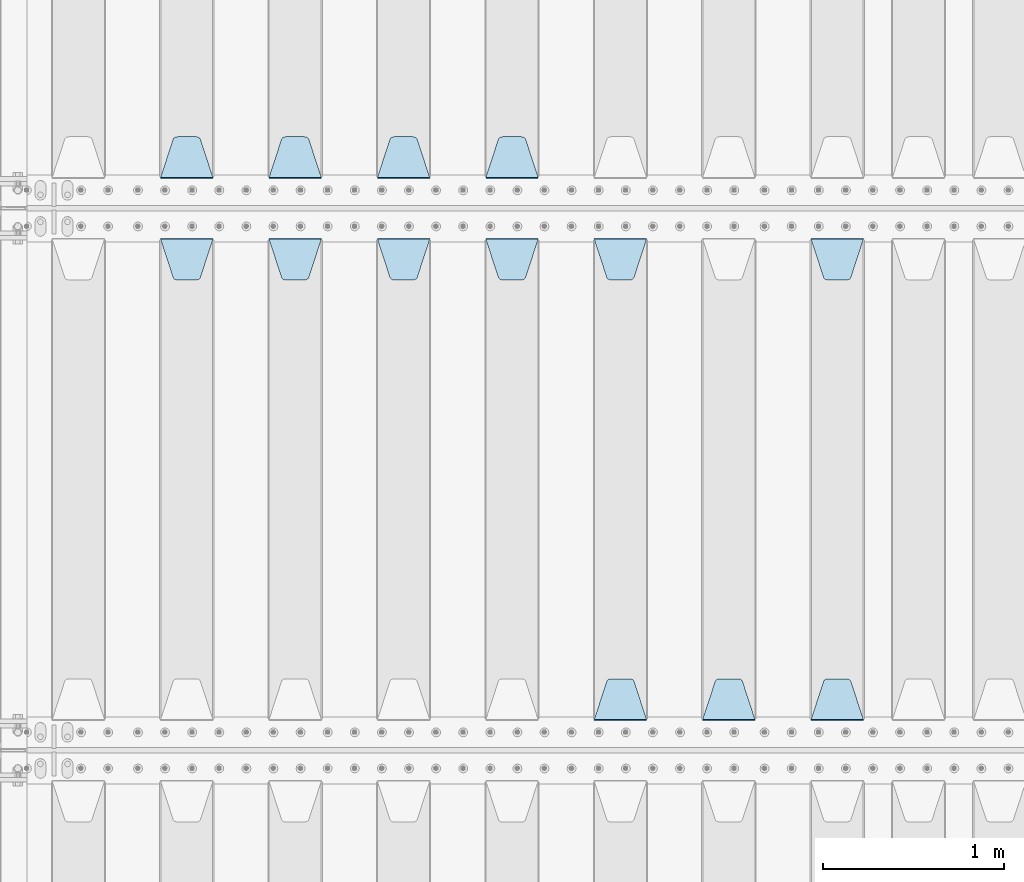
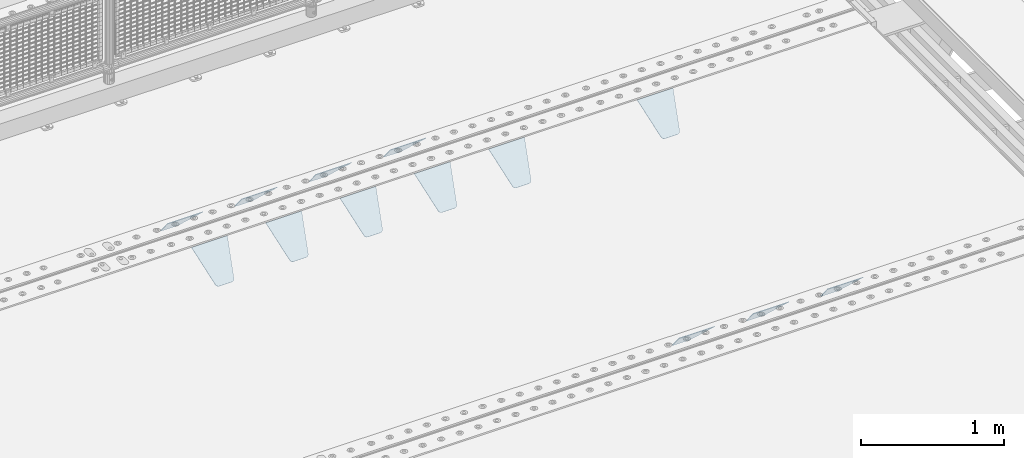
# One storey, part 245 of 270: 13 plates.
"""IFC2X3 building model written with IfcOpenShell, lengths in millimetres."""

from ifc_helpers import new_model, si_unit, frame, origin_with_axes, place, context, subcontext, project, spatial, faceted_brep, material, type_object, element, save


model = new_model("IFC2X3")

# Units and contexts
model_context = context("Model", 3, precision=1e-05, world=origin_with_axes())
body_context = subcontext(model_context, "Body", "Model", "MODEL_VIEW")
ifc_project = project(units=[si_unit("LENGTHUNIT", "METRE", prefix="MILLI"), si_unit("AREAUNIT", "SQUARE_METRE"), si_unit("VOLUMEUNIT", "CUBIC_METRE"), si_unit("MASSUNIT", "GRAM", prefix="KILO"), si_unit("TIMEUNIT", "SECOND"), si_unit("PLANEANGLEUNIT", "RADIAN"), si_unit("SOLIDANGLEUNIT", "STERADIAN"), si_unit("THERMODYNAMICTEMPERATUREUNIT", "DEGREE_CELSIUS"), si_unit("LUMINOUSINTENSITYUNIT", "LUMEN")], contexts=[model_context])

# Site, building, storey
site_placement = place(None, origin_with_axes())
site = spatial("IfcSite", under=ifc_project, at=site_placement, CompositionType="ELEMENT")
building_placement = place(site_placement, origin_with_axes())
building = spatial("IfcBuilding", under=site, at=building_placement, Name="Standard", CompositionType="ELEMENT")
storey_placement = place(building_placement, origin_with_axes())
storey = spatial("IfcBuildingStorey", under=building, at=storey_placement, Name="Undefined", CompositionType="ELEMENT", Elevation=0.0)

# Plates
ifc_material = material(Name="STEEL/S355N")
plate_type = type_object("IfcPlateType", PredefinedType="NOTDEFINED")
plate_1_placement = place(storey_placement, frame((17015.0, -17831.767766953, -1.76776695296758), z_axis=(0.0, 0.707106781186547, -0.707106781186548), x_axis=(-1.0, 0.0, 0.0)))
element("IfcPlate", 1, at=plate_1_placement, inside=storey, type_object=plate_type, material=ifc_material, context=body_context, shape_type="Brep", body=[
    faceted_brep([(0.0, -2.5, 0.0), (69.345504679477, -2.5, 300.171731424831), (69.345504679477, 2.5, 300.171731424831), (0.0, 2.5, 0.0), (70.9274061199576, -2.5, 304.8974424154), (70.9274061199576, 2.5, 304.8974424154), (73.3818627772307, -2.49999999999818, 309.234538108527), (73.3818627772307, 2.50000000000182, 309.234538108527), (76.6187032999551, -2.5, 313.023683126103), (76.6187032999551, 2.5, 313.023683126103), (80.5190132704993, -2.5, 316.125672595372), (80.5190132704993, 2.50000000000182, 316.125672595372), (84.9395038596849, -2.49999999999818, 318.426546230476), (84.9395038596849, 2.5, 318.426546230476), (89.7177759439219, -2.49999999999818, 319.841774983275), (89.7177759439219, 2.50000000000182, 319.841774983275), (94.678286292652, -2.5, 320.319366455078), (94.678286292652, 2.5, 320.319366455078), (195.321713707348, -2.5, 320.319366455078), (195.321713707348, 2.5, 320.319366455078), (200.282224056078, -2.49999999999818, 319.841774983275), (200.282224056078, 2.50000000000182, 319.841774983275), (205.060496140315, -2.5, 318.426546230476), (205.060496140315, 2.5, 318.426546230476), (209.480986729501, -2.5, 316.12567259537), (209.480986729501, 2.50000000000182, 316.12567259537), (213.381296700045, -2.5, 313.023683126103), (213.381296700045, 2.5, 313.023683126103), (216.618137222769, -2.49999999999818, 309.234538108525), (216.618137222769, 2.50000000000182, 309.234538108527), (219.072593880042, -2.49999999999818, 304.897442415398), (219.072593880042, 2.50000000000182, 304.897442415397), (220.654495320523, -2.5, 300.171731424831), (220.654495320523, 2.5, 300.171731424831), (290.0, -2.49999999999818, 0.0), (290.0, 2.5, 0.0)], [[[0, 1, 2, 3]], [[1, 4, 5, 2]], [[4, 6, 7, 5]], [[6, 8, 9, 7]], [[8, 10, 11, 9]], [[10, 12, 13, 11]], [[12, 14, 15, 13]], [[14, 16, 17, 15]], [[16, 18, 19, 17]], [[18, 20, 21, 19]], [[20, 22, 23, 21]], [[22, 24, 25, 23]], [[24, 26, 27, 25]], [[26, 28, 29, 27]], [[28, 30, 31, 29]], [[30, 32, 33, 31]], [[32, 34, 35, 33]], [[34, 0, 3, 35]], [[5, 7, 9, 11, 13, 15, 17, 19, 21, 23, 25, 27, 29, 31, 33, 35, 3, 2]], [[34, 32, 30, 28, 26, 24, 22, 20, 18, 16, 14, 12, 10, 8, 6, 4, 1, 0]]]),
])
plate_2_placement = place(storey_placement, frame((16415.0, -17831.767766953, -1.76776695296758), z_axis=(0.0, 0.707106781186547, -0.707106781186548), x_axis=(-1.0, 0.0, 0.0)))
element("IfcPlate", 2, at=plate_2_placement, inside=storey, type_object=plate_type, material=ifc_material, context=body_context, shape_type="Brep", body=[
    faceted_brep([(0.0, -2.5, 0.0), (69.345504679477, -2.5, 300.171731424831), (69.345504679477, 2.5, 300.171731424831), (0.0, 2.5, 0.0), (70.9274061199576, -2.5, 304.8974424154), (70.9274061199576, 2.5, 304.8974424154), (73.3818627772307, -2.49999999999818, 309.234538108527), (73.3818627772307, 2.50000000000182, 309.234538108527), (76.6187032999551, -2.5, 313.023683126103), (76.6187032999551, 2.5, 313.023683126103), (80.5190132704993, -2.5, 316.125672595372), (80.5190132704993, 2.50000000000182, 316.125672595372), (84.9395038596849, -2.49999999999818, 318.426546230476), (84.9395038596849, 2.5, 318.426546230476), (89.7177759439219, -2.49999999999818, 319.841774983275), (89.7177759439219, 2.50000000000182, 319.841774983275), (94.678286292652, -2.5, 320.319366455078), (94.678286292652, 2.5, 320.319366455078), (195.321713707348, -2.5, 320.319366455078), (195.321713707348, 2.5, 320.319366455078), (200.282224056078, -2.49999999999818, 319.841774983275), (200.282224056078, 2.50000000000182, 319.841774983275), (205.060496140315, -2.5, 318.426546230476), (205.060496140315, 2.5, 318.426546230476), (209.480986729501, -2.5, 316.12567259537), (209.480986729501, 2.50000000000182, 316.12567259537), (213.381296700045, -2.5, 313.023683126103), (213.381296700045, 2.5, 313.023683126103), (216.618137222769, -2.49999999999818, 309.234538108525), (216.618137222769, 2.50000000000182, 309.234538108527), (219.072593880042, -2.49999999999818, 304.897442415398), (219.072593880042, 2.50000000000182, 304.897442415397), (220.654495320523, -2.5, 300.171731424831), (220.654495320523, 2.5, 300.171731424831), (290.0, -2.49999999999818, 0.0), (290.0, 2.5, 0.0)], [[[0, 1, 2, 3]], [[1, 4, 5, 2]], [[4, 6, 7, 5]], [[6, 8, 9, 7]], [[8, 10, 11, 9]], [[10, 12, 13, 11]], [[12, 14, 15, 13]], [[14, 16, 17, 15]], [[16, 18, 19, 17]], [[18, 20, 21, 19]], [[20, 22, 23, 21]], [[22, 24, 25, 23]], [[24, 26, 27, 25]], [[26, 28, 29, 27]], [[28, 30, 31, 29]], [[30, 32, 33, 31]], [[32, 34, 35, 33]], [[34, 0, 3, 35]], [[5, 7, 9, 11, 13, 15, 17, 19, 21, 23, 25, 27, 29, 31, 33, 35, 3, 2]], [[34, 32, 30, 28, 26, 24, 22, 20, 18, 16, 14, 12, 10, 8, 6, 4, 1, 0]]]),
])
plate_3_placement = place(storey_placement, frame((15815.0, -17831.767766953, -1.76776695296758), z_axis=(0.0, 0.707106781186547, -0.707106781186548), x_axis=(-1.0, 0.0, 0.0)))
element("IfcPlate", 3, at=plate_3_placement, inside=storey, type_object=plate_type, material=ifc_material, context=body_context, shape_type="Brep", body=[
    faceted_brep([(0.0, -2.5, 0.0), (69.345504679477, -2.5, 300.171731424831), (69.345504679477, 2.5, 300.171731424831), (0.0, 2.5, 0.0), (70.9274061199576, -2.5, 304.8974424154), (70.9274061199576, 2.5, 304.8974424154), (73.3818627772307, -2.49999999999818, 309.234538108527), (73.3818627772307, 2.50000000000182, 309.234538108527), (76.6187032999551, -2.5, 313.023683126103), (76.6187032999551, 2.5, 313.023683126103), (80.5190132704993, -2.5, 316.125672595372), (80.5190132704993, 2.50000000000182, 316.125672595372), (84.9395038596849, -2.49999999999818, 318.426546230476), (84.9395038596849, 2.5, 318.426546230476), (89.7177759439219, -2.49999999999818, 319.841774983275), (89.7177759439219, 2.50000000000182, 319.841774983275), (94.678286292652, -2.5, 320.319366455078), (94.678286292652, 2.5, 320.319366455078), (195.321713707348, -2.5, 320.319366455078), (195.321713707348, 2.5, 320.319366455078), (200.282224056078, -2.49999999999818, 319.841774983275), (200.282224056078, 2.50000000000182, 319.841774983275), (205.060496140315, -2.5, 318.426546230476), (205.060496140315, 2.5, 318.426546230476), (209.480986729501, -2.5, 316.12567259537), (209.480986729501, 2.50000000000182, 316.12567259537), (213.381296700045, -2.5, 313.023683126103), (213.381296700045, 2.5, 313.023683126103), (216.618137222769, -2.49999999999818, 309.234538108525), (216.618137222769, 2.50000000000182, 309.234538108527), (219.072593880042, -2.49999999999818, 304.897442415398), (219.072593880042, 2.50000000000182, 304.897442415397), (220.654495320523, -2.5, 300.171731424831), (220.654495320523, 2.5, 300.171731424831), (290.0, -2.49999999999818, 0.0), (290.0, 2.5, 0.0)], [[[0, 1, 2, 3]], [[1, 4, 5, 2]], [[4, 6, 7, 5]], [[6, 8, 9, 7]], [[8, 10, 11, 9]], [[10, 12, 13, 11]], [[12, 14, 15, 13]], [[14, 16, 17, 15]], [[16, 18, 19, 17]], [[18, 20, 21, 19]], [[20, 22, 23, 21]], [[22, 24, 25, 23]], [[24, 26, 27, 25]], [[26, 28, 29, 27]], [[28, 30, 31, 29]], [[30, 32, 33, 31]], [[32, 34, 35, 33]], [[34, 0, 3, 35]], [[5, 7, 9, 11, 13, 15, 17, 19, 21, 23, 25, 27, 29, 31, 33, 35, 3, 2]], [[34, 32, 30, 28, 26, 24, 22, 20, 18, 16, 14, 12, 10, 8, 6, 4, 1, 0]]]),
])
plate_4_placement = place(storey_placement, frame((15215.0, -17831.767766953, -1.76776695296758), z_axis=(0.0, 0.707106781186547, -0.707106781186548), x_axis=(-1.0, 0.0, 0.0)))
element("IfcPlate", 4, at=plate_4_placement, inside=storey, type_object=plate_type, material=ifc_material, context=body_context, shape_type="Brep", body=[
    faceted_brep([(0.0, -2.5, 0.0), (69.345504679477, -2.5, 300.171731424831), (69.345504679477, 2.5, 300.171731424831), (0.0, 2.5, 0.0), (70.9274061199576, -2.5, 304.8974424154), (70.9274061199576, 2.5, 304.8974424154), (73.3818627772307, -2.49999999999818, 309.234538108527), (73.3818627772307, 2.50000000000182, 309.234538108527), (76.6187032999551, -2.5, 313.023683126103), (76.6187032999551, 2.5, 313.023683126103), (80.5190132704993, -2.5, 316.125672595372), (80.5190132704993, 2.50000000000182, 316.125672595372), (84.9395038596849, -2.49999999999818, 318.426546230476), (84.9395038596849, 2.5, 318.426546230476), (89.7177759439219, -2.49999999999818, 319.841774983275), (89.7177759439219, 2.50000000000182, 319.841774983275), (94.678286292652, -2.5, 320.319366455078), (94.678286292652, 2.5, 320.319366455078), (195.321713707348, -2.5, 320.319366455078), (195.321713707348, 2.5, 320.319366455078), (200.282224056078, -2.49999999999818, 319.841774983275), (200.282224056078, 2.50000000000182, 319.841774983275), (205.060496140315, -2.5, 318.426546230476), (205.060496140315, 2.5, 318.426546230476), (209.480986729501, -2.5, 316.12567259537), (209.480986729501, 2.50000000000182, 316.12567259537), (213.381296700045, -2.5, 313.023683126103), (213.381296700045, 2.5, 313.023683126103), (216.618137222769, -2.49999999999818, 309.234538108525), (216.618137222769, 2.50000000000182, 309.234538108527), (219.072593880042, -2.49999999999818, 304.897442415398), (219.072593880042, 2.50000000000182, 304.897442415397), (220.654495320523, -2.5, 300.171731424831), (220.654495320523, 2.5, 300.171731424831), (290.0, -2.49999999999818, 0.0), (290.0, 2.5, 0.0)], [[[0, 1, 2, 3]], [[1, 4, 5, 2]], [[4, 6, 7, 5]], [[6, 8, 9, 7]], [[8, 10, 11, 9]], [[10, 12, 13, 11]], [[12, 14, 15, 13]], [[14, 16, 17, 15]], [[16, 18, 19, 17]], [[18, 20, 21, 19]], [[20, 22, 23, 21]], [[22, 24, 25, 23]], [[24, 26, 27, 25]], [[26, 28, 29, 27]], [[28, 30, 31, 29]], [[30, 32, 33, 31]], [[32, 34, 35, 33]], [[34, 0, 3, 35]], [[5, 7, 9, 11, 13, 15, 17, 19, 21, 23, 25, 27, 29, 31, 33, 35, 3, 2]], [[34, 32, 30, 28, 26, 24, 22, 20, 18, 16, 14, 12, 10, 8, 6, 4, 1, 0]]]),
])
plate_5_placement = place(storey_placement, frame((18525.0, -18168.232233044, -1.76776695296576), z_axis=(0.0, -0.707106781186548, -0.707106781186547), x_axis=(1.0, 0.0, 0.0)))
element("IfcPlate", 5, at=plate_5_placement, inside=storey, type_object=plate_type, material=ifc_material, context=body_context, shape_type="Brep", body=[
    faceted_brep([(0.0, -2.5, 0.0), (69.345504679477, -2.5, 300.171731424831), (69.345504679477, 2.5, 300.171731424831), (0.0, 2.5, 0.0), (70.9274061199576, -2.5, 304.8974424154), (70.9274061199576, 2.5, 304.8974424154), (73.3818627772307, -2.49999999999818, 309.234538108527), (73.3818627772307, 2.50000000000182, 309.234538108527), (76.6187032999551, -2.5, 313.023683126103), (76.6187032999551, 2.5, 313.023683126103), (80.5190132704993, -2.5, 316.125672595372), (80.5190132704993, 2.50000000000182, 316.125672595372), (84.9395038596849, -2.49999999999818, 318.426546230476), (84.9395038596849, 2.5, 318.426546230476), (89.7177759439219, -2.49999999999818, 319.841774983275), (89.7177759439219, 2.50000000000182, 319.841774983275), (94.678286292652, -2.5, 320.319366455078), (94.678286292652, 2.5, 320.319366455078), (195.321713707348, -2.5, 320.319366455078), (195.321713707348, 2.5, 320.319366455078), (200.282224056078, -2.49999999999818, 319.841774983275), (200.282224056078, 2.50000000000182, 319.841774983275), (205.060496140315, -2.5, 318.426546230476), (205.060496140315, 2.5, 318.426546230476), (209.480986729501, -2.5, 316.12567259537), (209.480986729501, 2.50000000000182, 316.12567259537), (213.381296700045, -2.5, 313.023683126103), (213.381296700045, 2.5, 313.023683126103), (216.618137222769, -2.49999999999818, 309.234538108525), (216.618137222769, 2.50000000000182, 309.234538108527), (219.072593880042, -2.49999999999818, 304.897442415398), (219.072593880042, 2.50000000000182, 304.897442415397), (220.654495320523, -2.5, 300.171731424831), (220.654495320523, 2.5, 300.171731424831), (290.0, -2.49999999999818, 0.0), (290.0, 2.5, 0.0)], [[[0, 1, 2, 3]], [[1, 4, 5, 2]], [[4, 6, 7, 5]], [[6, 8, 9, 7]], [[8, 10, 11, 9]], [[10, 12, 13, 11]], [[12, 14, 15, 13]], [[14, 16, 17, 15]], [[16, 18, 19, 17]], [[18, 20, 21, 19]], [[20, 22, 23, 21]], [[22, 24, 25, 23]], [[24, 26, 27, 25]], [[26, 28, 29, 27]], [[28, 30, 31, 29]], [[30, 32, 33, 31]], [[32, 34, 35, 33]], [[34, 0, 3, 35]], [[5, 7, 9, 11, 13, 15, 17, 19, 21, 23, 25, 27, 29, 31, 33, 35, 3, 2]], [[34, 32, 30, 28, 26, 24, 22, 20, 18, 16, 14, 12, 10, 8, 6, 4, 1, 0]]]),
])
plate_6_placement = place(storey_placement, frame((18815.0, -20831.767766953, -1.76776695296758), z_axis=(0.0, 0.707106781186547, -0.707106781186548), x_axis=(-1.0, 0.0, 0.0)))
element("IfcPlate", 6, at=plate_6_placement, inside=storey, type_object=plate_type, material=ifc_material, context=body_context, shape_type="Brep", body=[
    faceted_brep([(0.0, -2.5, 0.0), (69.345504679477, -2.5, 300.171731424831), (69.345504679477, 2.5, 300.171731424831), (0.0, 2.5, 0.0), (70.9274061199576, -2.5, 304.8974424154), (70.9274061199576, 2.5, 304.8974424154), (73.3818627772307, -2.49999999999818, 309.234538108527), (73.3818627772307, 2.50000000000182, 309.234538108527), (76.6187032999551, -2.5, 313.023683126103), (76.6187032999551, 2.5, 313.023683126103), (80.5190132704993, -2.5, 316.125672595372), (80.5190132704993, 2.50000000000182, 316.125672595372), (84.9395038596849, -2.49999999999818, 318.426546230476), (84.9395038596849, 2.5, 318.426546230476), (89.7177759439219, -2.49999999999818, 319.841774983275), (89.7177759439219, 2.50000000000182, 319.841774983275), (94.678286292652, -2.5, 320.319366455078), (94.678286292652, 2.5, 320.319366455078), (195.321713707348, -2.5, 320.319366455078), (195.321713707348, 2.5, 320.319366455078), (200.282224056078, -2.49999999999818, 319.841774983275), (200.282224056078, 2.50000000000182, 319.841774983275), (205.060496140315, -2.5, 318.426546230476), (205.060496140315, 2.5, 318.426546230476), (209.480986729501, -2.5, 316.12567259537), (209.480986729501, 2.50000000000182, 316.12567259537), (213.381296700045, -2.5, 313.023683126103), (213.381296700045, 2.5, 313.023683126103), (216.618137222769, -2.49999999999818, 309.234538108525), (216.618137222769, 2.50000000000182, 309.234538108527), (219.072593880042, -2.49999999999818, 304.897442415398), (219.072593880042, 2.50000000000182, 304.897442415397), (220.654495320523, -2.5, 300.171731424831), (220.654495320523, 2.5, 300.171731424831), (290.0, -2.49999999999818, 0.0), (290.0, 2.5, 0.0)], [[[0, 1, 2, 3]], [[1, 4, 5, 2]], [[4, 6, 7, 5]], [[6, 8, 9, 7]], [[8, 10, 11, 9]], [[10, 12, 13, 11]], [[12, 14, 15, 13]], [[14, 16, 17, 15]], [[16, 18, 19, 17]], [[18, 20, 21, 19]], [[20, 22, 23, 21]], [[22, 24, 25, 23]], [[24, 26, 27, 25]], [[26, 28, 29, 27]], [[28, 30, 31, 29]], [[30, 32, 33, 31]], [[32, 34, 35, 33]], [[34, 0, 3, 35]], [[5, 7, 9, 11, 13, 15, 17, 19, 21, 23, 25, 27, 29, 31, 33, 35, 3, 2]], [[34, 32, 30, 28, 26, 24, 22, 20, 18, 16, 14, 12, 10, 8, 6, 4, 1, 0]]]),
])
plate_7_placement = place(storey_placement, frame((18215.0, -20831.767766953, -1.76776695296758), z_axis=(0.0, 0.707106781186547, -0.707106781186548), x_axis=(-1.0, 0.0, 0.0)))
element("IfcPlate", 7, at=plate_7_placement, inside=storey, type_object=plate_type, material=ifc_material, context=body_context, shape_type="Brep", body=[
    faceted_brep([(0.0, -2.5, 0.0), (69.345504679477, -2.5, 300.171731424831), (69.345504679477, 2.5, 300.171731424831), (0.0, 2.5, 0.0), (70.9274061199576, -2.5, 304.8974424154), (70.9274061199576, 2.5, 304.8974424154), (73.3818627772307, -2.49999999999818, 309.234538108527), (73.3818627772307, 2.50000000000182, 309.234538108527), (76.6187032999551, -2.5, 313.023683126103), (76.6187032999551, 2.5, 313.023683126103), (80.5190132704993, -2.5, 316.125672595372), (80.5190132704993, 2.50000000000182, 316.125672595372), (84.9395038596849, -2.49999999999818, 318.426546230476), (84.9395038596849, 2.5, 318.426546230476), (89.7177759439219, -2.49999999999818, 319.841774983275), (89.7177759439219, 2.50000000000182, 319.841774983275), (94.678286292652, -2.5, 320.319366455078), (94.678286292652, 2.5, 320.319366455078), (195.321713707348, -2.5, 320.319366455078), (195.321713707348, 2.5, 320.319366455078), (200.282224056078, -2.49999999999818, 319.841774983275), (200.282224056078, 2.50000000000182, 319.841774983275), (205.060496140315, -2.5, 318.426546230476), (205.060496140315, 2.5, 318.426546230476), (209.480986729501, -2.5, 316.12567259537), (209.480986729501, 2.50000000000182, 316.12567259537), (213.381296700045, -2.5, 313.023683126103), (213.381296700045, 2.5, 313.023683126103), (216.618137222769, -2.49999999999818, 309.234538108525), (216.618137222769, 2.50000000000182, 309.234538108527), (219.072593880042, -2.49999999999818, 304.897442415398), (219.072593880042, 2.50000000000182, 304.897442415397), (220.654495320523, -2.5, 300.171731424831), (220.654495320523, 2.5, 300.171731424831), (290.0, -2.49999999999818, 0.0), (290.0, 2.5, 0.0)], [[[0, 1, 2, 3]], [[1, 4, 5, 2]], [[4, 6, 7, 5]], [[6, 8, 9, 7]], [[8, 10, 11, 9]], [[10, 12, 13, 11]], [[12, 14, 15, 13]], [[14, 16, 17, 15]], [[16, 18, 19, 17]], [[18, 20, 21, 19]], [[20, 22, 23, 21]], [[22, 24, 25, 23]], [[24, 26, 27, 25]], [[26, 28, 29, 27]], [[28, 30, 31, 29]], [[30, 32, 33, 31]], [[32, 34, 35, 33]], [[34, 0, 3, 35]], [[5, 7, 9, 11, 13, 15, 17, 19, 21, 23, 25, 27, 29, 31, 33, 35, 3, 2]], [[34, 32, 30, 28, 26, 24, 22, 20, 18, 16, 14, 12, 10, 8, 6, 4, 1, 0]]]),
])
plate_8_placement = place(storey_placement, frame((17325.0, -18168.232233044, -1.76776695296576), z_axis=(0.0, -0.707106781186548, -0.707106781186547), x_axis=(1.0, 0.0, 0.0)))
element("IfcPlate", 8, at=plate_8_placement, inside=storey, type_object=plate_type, material=ifc_material, context=body_context, shape_type="Brep", body=[
    faceted_brep([(0.0, -2.5, 0.0), (69.345504679477, -2.5, 300.171731424831), (69.345504679477, 2.5, 300.171731424831), (0.0, 2.5, 0.0), (70.9274061199576, -2.5, 304.8974424154), (70.9274061199576, 2.5, 304.8974424154), (73.3818627772307, -2.49999999999818, 309.234538108527), (73.3818627772307, 2.50000000000182, 309.234538108527), (76.6187032999551, -2.5, 313.023683126103), (76.6187032999551, 2.5, 313.023683126103), (80.5190132704993, -2.5, 316.125672595372), (80.5190132704993, 2.50000000000182, 316.125672595372), (84.9395038596849, -2.49999999999818, 318.426546230476), (84.9395038596849, 2.5, 318.426546230476), (89.7177759439219, -2.49999999999818, 319.841774983275), (89.7177759439219, 2.50000000000182, 319.841774983275), (94.678286292652, -2.5, 320.319366455078), (94.678286292652, 2.5, 320.319366455078), (195.321713707348, -2.5, 320.319366455078), (195.321713707348, 2.5, 320.319366455078), (200.282224056078, -2.49999999999818, 319.841774983275), (200.282224056078, 2.50000000000182, 319.841774983275), (205.060496140315, -2.5, 318.426546230476), (205.060496140315, 2.5, 318.426546230476), (209.480986729501, -2.5, 316.12567259537), (209.480986729501, 2.50000000000182, 316.12567259537), (213.381296700045, -2.5, 313.023683126103), (213.381296700045, 2.5, 313.023683126103), (216.618137222769, -2.49999999999818, 309.234538108525), (216.618137222769, 2.50000000000182, 309.234538108527), (219.072593880042, -2.49999999999818, 304.897442415398), (219.072593880042, 2.50000000000182, 304.897442415397), (220.654495320523, -2.5, 300.171731424831), (220.654495320523, 2.5, 300.171731424831), (290.0, -2.49999999999818, 0.0), (290.0, 2.5, 0.0)], [[[0, 1, 2, 3]], [[1, 4, 5, 2]], [[4, 6, 7, 5]], [[6, 8, 9, 7]], [[8, 10, 11, 9]], [[10, 12, 13, 11]], [[12, 14, 15, 13]], [[14, 16, 17, 15]], [[16, 18, 19, 17]], [[18, 20, 21, 19]], [[20, 22, 23, 21]], [[22, 24, 25, 23]], [[24, 26, 27, 25]], [[26, 28, 29, 27]], [[28, 30, 31, 29]], [[30, 32, 33, 31]], [[32, 34, 35, 33]], [[34, 0, 3, 35]], [[5, 7, 9, 11, 13, 15, 17, 19, 21, 23, 25, 27, 29, 31, 33, 35, 3, 2]], [[34, 32, 30, 28, 26, 24, 22, 20, 18, 16, 14, 12, 10, 8, 6, 4, 1, 0]]]),
])
plate_9_placement = place(storey_placement, frame((17615.0, -20831.767766953, -1.76776695296758), z_axis=(0.0, 0.707106781186547, -0.707106781186548), x_axis=(-1.0, 0.0, 0.0)))
element("IfcPlate", 9, at=plate_9_placement, inside=storey, type_object=plate_type, material=ifc_material, context=body_context, shape_type="Brep", body=[
    faceted_brep([(0.0, -2.5, 0.0), (69.345504679477, -2.5, 300.171731424831), (69.345504679477, 2.5, 300.171731424831), (0.0, 2.5, 0.0), (70.9274061199576, -2.5, 304.8974424154), (70.9274061199576, 2.5, 304.8974424154), (73.3818627772307, -2.49999999999818, 309.234538108527), (73.3818627772307, 2.50000000000182, 309.234538108527), (76.6187032999551, -2.5, 313.023683126103), (76.6187032999551, 2.5, 313.023683126103), (80.5190132704993, -2.5, 316.125672595372), (80.5190132704993, 2.50000000000182, 316.125672595372), (84.9395038596849, -2.49999999999818, 318.426546230476), (84.9395038596849, 2.5, 318.426546230476), (89.7177759439219, -2.49999999999818, 319.841774983275), (89.7177759439219, 2.50000000000182, 319.841774983275), (94.678286292652, -2.5, 320.319366455078), (94.678286292652, 2.5, 320.319366455078), (195.321713707348, -2.5, 320.319366455078), (195.321713707348, 2.5, 320.319366455078), (200.282224056078, -2.49999999999818, 319.841774983275), (200.282224056078, 2.50000000000182, 319.841774983275), (205.060496140315, -2.5, 318.426546230476), (205.060496140315, 2.5, 318.426546230476), (209.480986729501, -2.5, 316.12567259537), (209.480986729501, 2.50000000000182, 316.12567259537), (213.381296700045, -2.5, 313.023683126103), (213.381296700045, 2.5, 313.023683126103), (216.618137222769, -2.49999999999818, 309.234538108525), (216.618137222769, 2.50000000000182, 309.234538108527), (219.072593880042, -2.49999999999818, 304.897442415398), (219.072593880042, 2.50000000000182, 304.897442415397), (220.654495320523, -2.5, 300.171731424831), (220.654495320523, 2.5, 300.171731424831), (290.0, -2.49999999999818, 0.0), (290.0, 2.5, 0.0)], [[[0, 1, 2, 3]], [[1, 4, 5, 2]], [[4, 6, 7, 5]], [[6, 8, 9, 7]], [[8, 10, 11, 9]], [[10, 12, 13, 11]], [[12, 14, 15, 13]], [[14, 16, 17, 15]], [[16, 18, 19, 17]], [[18, 20, 21, 19]], [[20, 22, 23, 21]], [[22, 24, 25, 23]], [[24, 26, 27, 25]], [[26, 28, 29, 27]], [[28, 30, 31, 29]], [[30, 32, 33, 31]], [[32, 34, 35, 33]], [[34, 0, 3, 35]], [[5, 7, 9, 11, 13, 15, 17, 19, 21, 23, 25, 27, 29, 31, 33, 35, 3, 2]], [[34, 32, 30, 28, 26, 24, 22, 20, 18, 16, 14, 12, 10, 8, 6, 4, 1, 0]]]),
])
plate_10_placement = place(storey_placement, frame((16725.0, -18168.232233044, -1.76776695296576), z_axis=(0.0, -0.707106781186548, -0.707106781186547), x_axis=(1.0, 0.0, 0.0)))
element("IfcPlate", 10, at=plate_10_placement, inside=storey, type_object=plate_type, material=ifc_material, context=body_context, shape_type="Brep", body=[
    faceted_brep([(0.0, -2.5, 0.0), (69.345504679477, -2.5, 300.171731424831), (69.345504679477, 2.5, 300.171731424831), (0.0, 2.5, 0.0), (70.9274061199576, -2.5, 304.8974424154), (70.9274061199576, 2.5, 304.8974424154), (73.3818627772307, -2.49999999999818, 309.234538108527), (73.3818627772307, 2.50000000000182, 309.234538108527), (76.6187032999551, -2.5, 313.023683126103), (76.6187032999551, 2.5, 313.023683126103), (80.5190132704993, -2.5, 316.125672595372), (80.5190132704993, 2.50000000000182, 316.125672595372), (84.9395038596849, -2.49999999999818, 318.426546230476), (84.9395038596849, 2.5, 318.426546230476), (89.7177759439219, -2.49999999999818, 319.841774983275), (89.7177759439219, 2.50000000000182, 319.841774983275), (94.678286292652, -2.5, 320.319366455078), (94.678286292652, 2.5, 320.319366455078), (195.321713707348, -2.5, 320.319366455078), (195.321713707348, 2.5, 320.319366455078), (200.282224056078, -2.49999999999818, 319.841774983275), (200.282224056078, 2.50000000000182, 319.841774983275), (205.060496140315, -2.5, 318.426546230476), (205.060496140315, 2.5, 318.426546230476), (209.480986729501, -2.5, 316.12567259537), (209.480986729501, 2.50000000000182, 316.12567259537), (213.381296700045, -2.5, 313.023683126103), (213.381296700045, 2.5, 313.023683126103), (216.618137222769, -2.49999999999818, 309.234538108525), (216.618137222769, 2.50000000000182, 309.234538108527), (219.072593880042, -2.49999999999818, 304.897442415398), (219.072593880042, 2.50000000000182, 304.897442415397), (220.654495320523, -2.5, 300.171731424831), (220.654495320523, 2.5, 300.171731424831), (290.0, -2.49999999999818, 0.0), (290.0, 2.5, 0.0)], [[[0, 1, 2, 3]], [[1, 4, 5, 2]], [[4, 6, 7, 5]], [[6, 8, 9, 7]], [[8, 10, 11, 9]], [[10, 12, 13, 11]], [[12, 14, 15, 13]], [[14, 16, 17, 15]], [[16, 18, 19, 17]], [[18, 20, 21, 19]], [[20, 22, 23, 21]], [[22, 24, 25, 23]], [[24, 26, 27, 25]], [[26, 28, 29, 27]], [[28, 30, 31, 29]], [[30, 32, 33, 31]], [[32, 34, 35, 33]], [[34, 0, 3, 35]], [[5, 7, 9, 11, 13, 15, 17, 19, 21, 23, 25, 27, 29, 31, 33, 35, 3, 2]], [[34, 32, 30, 28, 26, 24, 22, 20, 18, 16, 14, 12, 10, 8, 6, 4, 1, 0]]]),
])
plate_11_placement = place(storey_placement, frame((16125.0, -18168.232233044, -1.76776695296576), z_axis=(0.0, -0.707106781186548, -0.707106781186547), x_axis=(1.0, 0.0, 0.0)))
element("IfcPlate", 11, at=plate_11_placement, inside=storey, type_object=plate_type, material=ifc_material, context=body_context, shape_type="Brep", body=[
    faceted_brep([(0.0, -2.5, 0.0), (69.345504679477, -2.5, 300.171731424831), (69.345504679477, 2.5, 300.171731424831), (0.0, 2.5, 0.0), (70.9274061199576, -2.5, 304.8974424154), (70.9274061199576, 2.5, 304.8974424154), (73.3818627772307, -2.49999999999818, 309.234538108527), (73.3818627772307, 2.50000000000182, 309.234538108527), (76.6187032999551, -2.5, 313.023683126103), (76.6187032999551, 2.5, 313.023683126103), (80.5190132704993, -2.5, 316.125672595372), (80.5190132704993, 2.50000000000182, 316.125672595372), (84.9395038596849, -2.49999999999818, 318.426546230476), (84.9395038596849, 2.5, 318.426546230476), (89.7177759439219, -2.49999999999818, 319.841774983275), (89.7177759439219, 2.50000000000182, 319.841774983275), (94.678286292652, -2.5, 320.319366455078), (94.678286292652, 2.5, 320.319366455078), (195.321713707348, -2.5, 320.319366455078), (195.321713707348, 2.5, 320.319366455078), (200.282224056078, -2.49999999999818, 319.841774983275), (200.282224056078, 2.50000000000182, 319.841774983275), (205.060496140315, -2.5, 318.426546230476), (205.060496140315, 2.5, 318.426546230476), (209.480986729501, -2.5, 316.12567259537), (209.480986729501, 2.50000000000182, 316.12567259537), (213.381296700045, -2.5, 313.023683126103), (213.381296700045, 2.5, 313.023683126103), (216.618137222769, -2.49999999999818, 309.234538108525), (216.618137222769, 2.50000000000182, 309.234538108527), (219.072593880042, -2.49999999999818, 304.897442415398), (219.072593880042, 2.50000000000182, 304.897442415397), (220.654495320523, -2.5, 300.171731424831), (220.654495320523, 2.5, 300.171731424831), (290.0, -2.49999999999818, 0.0), (290.0, 2.5, 0.0)], [[[0, 1, 2, 3]], [[1, 4, 5, 2]], [[4, 6, 7, 5]], [[6, 8, 9, 7]], [[8, 10, 11, 9]], [[10, 12, 13, 11]], [[12, 14, 15, 13]], [[14, 16, 17, 15]], [[16, 18, 19, 17]], [[18, 20, 21, 19]], [[20, 22, 23, 21]], [[22, 24, 25, 23]], [[24, 26, 27, 25]], [[26, 28, 29, 27]], [[28, 30, 31, 29]], [[30, 32, 33, 31]], [[32, 34, 35, 33]], [[34, 0, 3, 35]], [[5, 7, 9, 11, 13, 15, 17, 19, 21, 23, 25, 27, 29, 31, 33, 35, 3, 2]], [[34, 32, 30, 28, 26, 24, 22, 20, 18, 16, 14, 12, 10, 8, 6, 4, 1, 0]]]),
])
plate_12_placement = place(storey_placement, frame((15525.0, -18168.232233044, -1.76776695296576), z_axis=(0.0, -0.707106781186548, -0.707106781186547), x_axis=(1.0, 0.0, 0.0)))
element("IfcPlate", 12, at=plate_12_placement, inside=storey, type_object=plate_type, material=ifc_material, context=body_context, shape_type="Brep", body=[
    faceted_brep([(0.0, -2.5, 0.0), (69.345504679477, -2.5, 300.171731424831), (69.345504679477, 2.5, 300.171731424831), (0.0, 2.5, 0.0), (70.9274061199576, -2.5, 304.8974424154), (70.9274061199576, 2.5, 304.8974424154), (73.3818627772307, -2.49999999999818, 309.234538108527), (73.3818627772307, 2.50000000000182, 309.234538108527), (76.6187032999551, -2.5, 313.023683126103), (76.6187032999551, 2.5, 313.023683126103), (80.5190132704993, -2.5, 316.125672595372), (80.5190132704993, 2.50000000000182, 316.125672595372), (84.9395038596849, -2.49999999999818, 318.426546230476), (84.9395038596849, 2.5, 318.426546230476), (89.7177759439219, -2.49999999999818, 319.841774983275), (89.7177759439219, 2.50000000000182, 319.841774983275), (94.678286292652, -2.5, 320.319366455078), (94.678286292652, 2.5, 320.319366455078), (195.321713707348, -2.5, 320.319366455078), (195.321713707348, 2.5, 320.319366455078), (200.282224056078, -2.49999999999818, 319.841774983275), (200.282224056078, 2.50000000000182, 319.841774983275), (205.060496140315, -2.5, 318.426546230476), (205.060496140315, 2.5, 318.426546230476), (209.480986729501, -2.5, 316.12567259537), (209.480986729501, 2.50000000000182, 316.12567259537), (213.381296700045, -2.5, 313.023683126103), (213.381296700045, 2.5, 313.023683126103), (216.618137222769, -2.49999999999818, 309.234538108525), (216.618137222769, 2.50000000000182, 309.234538108527), (219.072593880042, -2.49999999999818, 304.897442415398), (219.072593880042, 2.50000000000182, 304.897442415397), (220.654495320523, -2.5, 300.171731424831), (220.654495320523, 2.5, 300.171731424831), (290.0, -2.49999999999818, 0.0), (290.0, 2.5, 0.0)], [[[0, 1, 2, 3]], [[1, 4, 5, 2]], [[4, 6, 7, 5]], [[6, 8, 9, 7]], [[8, 10, 11, 9]], [[10, 12, 13, 11]], [[12, 14, 15, 13]], [[14, 16, 17, 15]], [[16, 18, 19, 17]], [[18, 20, 21, 19]], [[20, 22, 23, 21]], [[22, 24, 25, 23]], [[24, 26, 27, 25]], [[26, 28, 29, 27]], [[28, 30, 31, 29]], [[30, 32, 33, 31]], [[32, 34, 35, 33]], [[34, 0, 3, 35]], [[5, 7, 9, 11, 13, 15, 17, 19, 21, 23, 25, 27, 29, 31, 33, 35, 3, 2]], [[34, 32, 30, 28, 26, 24, 22, 20, 18, 16, 14, 12, 10, 8, 6, 4, 1, 0]]]),
])
plate_13_placement = place(storey_placement, frame((14925.0, -18168.232233044, -1.76776695296576), z_axis=(0.0, -0.707106781186548, -0.707106781186547), x_axis=(1.0, 0.0, 0.0)))
element("IfcPlate", 13, at=plate_13_placement, inside=storey, type_object=plate_type, material=ifc_material, context=body_context, shape_type="Brep", body=[
    faceted_brep([(0.0, -2.5, 0.0), (69.345504679477, -2.5, 300.171731424831), (69.345504679477, 2.5, 300.171731424831), (0.0, 2.5, 0.0), (70.9274061199576, -2.5, 304.8974424154), (70.9274061199576, 2.5, 304.8974424154), (73.3818627772307, -2.49999999999818, 309.234538108527), (73.3818627772307, 2.50000000000182, 309.234538108527), (76.6187032999551, -2.5, 313.023683126103), (76.6187032999551, 2.5, 313.023683126103), (80.5190132704993, -2.5, 316.125672595372), (80.5190132704993, 2.50000000000182, 316.125672595372), (84.9395038596849, -2.49999999999818, 318.426546230476), (84.9395038596849, 2.5, 318.426546230476), (89.7177759439219, -2.49999999999818, 319.841774983275), (89.7177759439219, 2.50000000000182, 319.841774983275), (94.678286292652, -2.5, 320.319366455078), (94.678286292652, 2.5, 320.319366455078), (195.321713707348, -2.5, 320.319366455078), (195.321713707348, 2.5, 320.319366455078), (200.282224056078, -2.49999999999818, 319.841774983275), (200.282224056078, 2.50000000000182, 319.841774983275), (205.060496140315, -2.5, 318.426546230476), (205.060496140315, 2.5, 318.426546230476), (209.480986729501, -2.5, 316.12567259537), (209.480986729501, 2.50000000000182, 316.12567259537), (213.381296700045, -2.5, 313.023683126103), (213.381296700045, 2.5, 313.023683126103), (216.618137222769, -2.49999999999818, 309.234538108525), (216.618137222769, 2.50000000000182, 309.234538108527), (219.072593880042, -2.49999999999818, 304.897442415398), (219.072593880042, 2.50000000000182, 304.897442415397), (220.654495320523, -2.5, 300.171731424831), (220.654495320523, 2.5, 300.171731424831), (290.0, -2.49999999999818, 0.0), (290.0, 2.5, 0.0)], [[[0, 1, 2, 3]], [[1, 4, 5, 2]], [[4, 6, 7, 5]], [[6, 8, 9, 7]], [[8, 10, 11, 9]], [[10, 12, 13, 11]], [[12, 14, 15, 13]], [[14, 16, 17, 15]], [[16, 18, 19, 17]], [[18, 20, 21, 19]], [[20, 22, 23, 21]], [[22, 24, 25, 23]], [[24, 26, 27, 25]], [[26, 28, 29, 27]], [[28, 30, 31, 29]], [[30, 32, 33, 31]], [[32, 34, 35, 33]], [[34, 0, 3, 35]], [[5, 7, 9, 11, 13, 15, 17, 19, 21, 23, 25, 27, 29, 31, 33, 35, 3, 2]], [[34, 32, 30, 28, 26, 24, 22, 20, 18, 16, 14, 12, 10, 8, 6, 4, 1, 0]]]),
])

save(model, "model.ifc")
